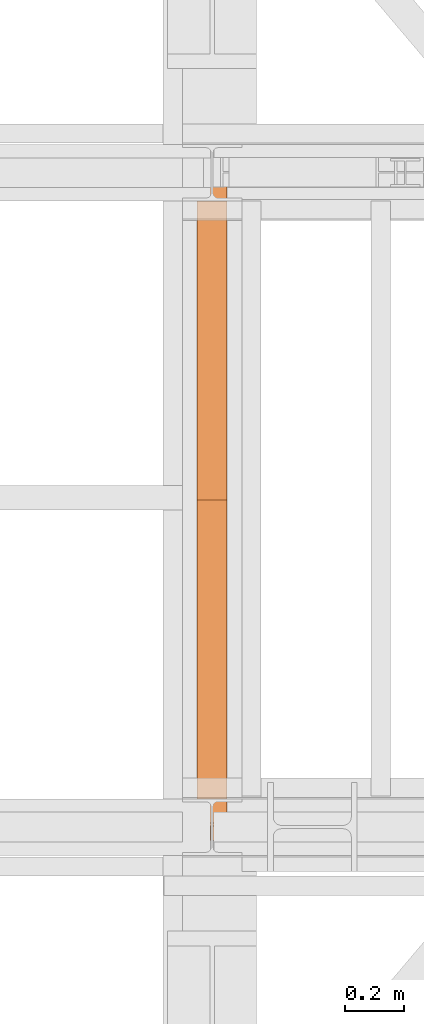
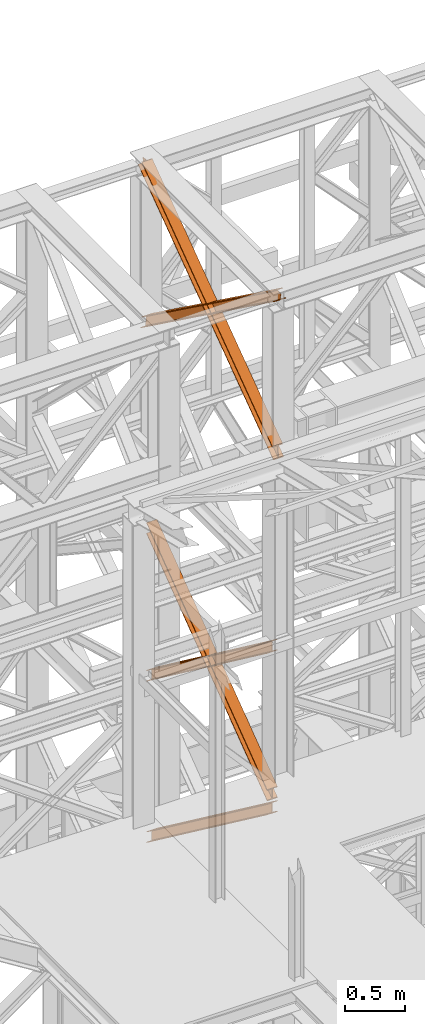
# One storey, part 125 of 208: 5 proxies.
"""IFC2X3 building model written with IfcOpenShell, lengths in millimetres."""

from ifc_helpers import new_model, entity, si_unit, converted_unit, frame, origin, origin_with_axes, place, context, subcontext, project, spatial, faceted_brep, element, save


model = new_model("IFC2X3")

# Units and contexts
model_context = context("Model", 3, precision=1e-05, world=origin())
plan_context = context("Plan", 3, precision=1e-05, world=origin())
body_context = subcontext(model_context, "Body", "Model", "MODEL_VIEW")
ifc_project = project(units=[si_unit("LENGTHUNIT", "METRE", prefix="MILLI"), converted_unit("PLANEANGLEUNIT", "DEGREE", entity("IfcPlaneAngleMeasure", 0.0174532925199433), si_unit("PLANEANGLEUNIT", "RADIAN"), dimensions=[0, 0, 0, 0, 0, 0, 0]), si_unit("AREAUNIT", "SQUARE_METRE"), si_unit("VOLUMEUNIT", "CUBIC_METRE")], contexts=[model_context, plan_context])

# Building, storey
building_placement = place(None, origin())
building = spatial("IfcBuilding", under=ifc_project, at=building_placement, CompositionType="COMPLEX")
storey_placement = place(building_placement, origin_with_axes())
storey = spatial("IfcBuildingStorey", under=building, at=storey_placement, Name="Geschoss", CompositionType="ELEMENT")

# Proxies
proxy_1_placement = place(storey_placement, frame((3243.082676642578, -15867.5743840594, 5504.219540188055), z_axis=(0.0, 0.0, 1.0), x_axis=(1.0, 0.0, 0.0)))
element("IfcBuildingElementProxy", 1, at=proxy_1_placement, inside=storey, context=body_context, shape_type="Brep", body=[
    faceted_brep([(100.0218596475406, 0.01000000000021828, 1511.076608371926), (100.1844513161013, 2010.009987483025, 9.820176864343011), (100.1855295209298, 2010.009987483025, 0.02100513655932446), (100.0229378523673, 0.01000000000021828, 1501.277436644132), (100.0229378523673, 0.01000000000021828, 1501.277436644132), (100.1855295209298, 2010.009987483025, 0.02100513655932446), (0.1855301264913578, 2010.009987483025, 0.01000000000021828), (0.02293845793246874, 0.01000000000021828, 1501.266431507576), (0.02293845793246874, 0.01000000000021828, 1501.266431507576), (0.1855301264913578, 2010.009987483025, 0.01000000000021828), (0.1844519216665503, 2010.009987483025, 9.809171727787543), (0.02186025310402329, 0.01000000000021828, 1511.06560323536), (0.02186025310402329, 0.01000000000021828, 1511.06560323536), (0.1844519216665503, 2010.009987483025, 9.809171727787543), (47.6844516340243, 2010.009987483025, 9.814399167646116), (47.52185996546359, 0.01000000000021828, 1511.070830675226), (47.52185996546359, 0.01000000000021828, 1511.070830675226), (47.6844516340243, 2010.009987483025, 9.814399167646116), (47.6736695857453, 2010.009987483025, 107.8061164454975), (47.51107791718459, 0.01000000000021828, 1609.062547953077), (47.51107791718459, 0.01000000000021828, 1609.062547953077), (47.6736695857453, 2010.009987483025, 107.8061164454975), (0.1736698733893718, 2010.009987483025, 107.8008890056317), (0.01107820482866373, 0.01000000000021828, 1609.057320513211), (0.01107820482866373, 0.01000000000021828, 1609.057320513211), (0.1736698733893718, 2010.009987483025, 107.8008890056317), (0.1725916685609263, 2010.009987483025, 117.6000607334227), (0.01000000000021828, 0.01000000000021828, 1618.856492240995), (0.01000000000021828, 0.01000000000021828, 1618.856492240995), (0.1725916685609263, 2010.009987483025, 117.6000607334227), (100.1725910629975, 2010.009987483025, 117.6110658699781), (100.009999394435, 0.01000000000021828, 1618.867497377558), (100.009999394435, 0.01000000000021828, 1618.867497377558), (100.1725910629975, 2010.009987483025, 117.6110658699781), (100.1736692678242, 2010.009987483025, 107.8118941421981), (100.0110775992634, 0.01000000000021828, 1609.068325649774), (100.0110775992634, 0.01000000000021828, 1609.068325649774), (100.1736692678242, 2010.009987483025, 107.8118941421981), (52.67366955546459, 2010.009987483025, 107.806666702325), (52.51107788690388, 0.01000000000021828, 1609.063098209905), (52.51107788690388, 0.01000000000021828, 1609.063098209905), (52.67366955546459, 2010.009987483025, 107.806666702325), (52.6844516037454, 2010.009987483025, 9.814949424477163), (52.52185993518287, 0.01000000000021828, 1511.071380932057), (52.52185993518287, 0.01000000000021828, 1511.071380932057), (52.6844516037454, 2010.009987483025, 9.814949424477163), (100.1844513161013, 2010.009987483025, 9.820176864343011), (100.0218596475406, 0.01000000000021828, 1511.076608371926), (100.1844513161013, 2010.009987483025, 9.820176864343011), (52.6844516037454, 2010.009987483025, 9.814949424477163), (52.67366955546459, 2010.009987483025, 107.806666702325), (100.1736692678242, 2010.009987483025, 107.8118941421981), (100.1725910629975, 2010.009987483025, 117.6110658699781), (0.1725916685609263, 2010.009987483025, 117.6000607334227), (0.1736698733893718, 2010.009987483025, 107.8008890056317), (47.6736695857453, 2010.009987483025, 107.8061164454975), (47.6844516340243, 2010.009987483025, 9.814399167646116), (0.1844519216665503, 2010.009987483025, 9.809171727787543), (0.1855301264913578, 2010.009987483025, 0.01000000000021828), (100.1855295209298, 2010.009987483025, 0.02100513655932446), (100.0229378523673, 0.01000000000021828, 1501.277436644132), (0.02293845793246874, 0.01000000000021828, 1501.266431507576), (0.02186025310402329, 0.01000000000021828, 1511.06560323536), (47.52185996546359, 0.01000000000021828, 1511.070830675226), (47.51107791718459, 0.01000000000021828, 1609.062547953077), (0.01107820482866373, 0.01000000000021828, 1609.057320513211), (0.01000000000021828, 0.01000000000021828, 1618.856492240995), (100.009999394435, 0.01000000000021828, 1618.867497377558), (100.0110775992634, 0.01000000000021828, 1609.068325649774), (52.51107788690388, 0.01000000000021828, 1609.063098209905), (52.52185993518287, 0.01000000000021828, 1511.071380932057), (100.0218596475406, 0.01000000000021828, 1511.076608371926)], [[[0, 1, 2, 3]], [[4, 5, 6, 7]], [[8, 9, 10, 11]], [[12, 13, 14, 15]], [[16, 17, 18, 19]], [[20, 21, 22, 23]], [[24, 25, 26, 27]], [[28, 29, 30, 31]], [[32, 33, 34, 35]], [[36, 37, 38, 39]], [[40, 41, 42, 43]], [[44, 45, 46, 47]], [[48, 49, 50, 51, 52, 53, 54, 55, 56, 57, 58, 59]], [[60, 61, 62, 63, 64, 65, 66, 67, 68, 69, 70, 71]]], orient=[[False], [False], [False], [False], [False], [False], [False], [False], [False], [False], [False], [False], [False], [False]]),
])
proxy_2_placement = place(storey_placement, frame((3242.895475356376, -15867.5743840594, 7147.441290649187), z_axis=(0.0, 0.0, 1.0), x_axis=(1.0, 0.0, 0.0)))
element("IfcBuildingElementProxy", 2, at=proxy_2_placement, inside=storey, context=body_context, shape_type="Brep", body=[
    faceted_brep([(100.0218623025612, 0.01000000000021828, 1512.063556389601), (100.1844166626906, 2010.009987483025, 9.822513400360549), (100.1854951088862, 2010.009987483025, 0.02100513655932446), (100.022940748755, 0.01000000000021828, 1502.262048125804), (100.022940748755, 0.01000000000021828, 1502.262048125804), (100.1854951088862, 2010.009987483025, 0.02100513655932446), (0.1854957144514629, 2010.009987483025, 0.01000000000021828), (0.02294135431839095, 0.01000000000021828, 1502.251042989237), (0.02294135431839095, 0.01000000000021828, 1502.251042989237), (0.1854957144514629, 2010.009987483025, 0.01000000000021828), (0.1844172682558565, 2010.009987483025, 9.811508263797805), (0.02186290812642255, 0.01000000000021828, 1512.052551253039), (0.02186290812642255, 0.01000000000021828, 1512.052551253039), (0.1844172682558565, 2010.009987483025, 9.811508263797805), (47.68441698061361, 2010.009987483025, 9.816735703663653), (47.52186262048235, 0.01000000000021828, 1512.057778692908), (47.52186262048235, 0.01000000000021828, 1512.057778692908), (47.68441698061361, 2010.009987483025, 9.816735703663653), (47.67363251868483, 2010.009987483025, 107.8318183416577), (47.51107815855175, 0.01000000000021828, 1610.072861330906), (47.51107815855175, 0.01000000000021828, 1610.072861330906), (47.67363251868483, 2010.009987483025, 107.8318183416577), (0.1736328063252586, 2010.009987483025, 107.8265909017955), (0.01107844619582465, 0.01000000000021828, 1610.067633891033), (0.01107844619582465, 0.01000000000021828, 1610.067633891033), (0.1736328063252586, 2010.009987483025, 107.8265909017955), (0.1725543601314712, 2010.009987483025, 117.6280991655931), (0.01000000000021828, 0.01000000000021828, 1619.86914215483), (0.01000000000021828, 0.01000000000021828, 1619.86914215483), (0.1725543601314712, 2010.009987483025, 117.6280991655931), (100.1725537545663, 2010.009987483025, 117.6391043021558), (100.009999394435, 0.01000000000021828, 1619.880147291397), (100.009999394435, 0.01000000000021828, 1619.880147291397), (100.1725537545663, 2010.009987483025, 117.6391043021558), (100.1736322007619, 2010.009987483025, 107.8375960383546), (100.0110778406306, 0.01000000000021828, 1610.078639027603), (100.0110778406306, 0.01000000000021828, 1610.078639027603), (100.1736322007619, 2010.009987483025, 107.8375960383546), (52.67363248840411, 2010.009987483025, 107.8323685984888), (52.51107812827468, 0.01000000000021828, 1610.073411587733), (52.51107812827468, 0.01000000000021828, 1610.073411587733), (52.67363248840411, 2010.009987483025, 107.8323685984888), (52.68441695033471, 2010.009987483025, 9.817285960491063), (52.52186259020346, 0.01000000000021828, 1512.058328949732), (52.52186259020346, 0.01000000000021828, 1512.058328949732), (52.68441695033471, 2010.009987483025, 9.817285960491063), (100.1844166626906, 2010.009987483025, 9.822513400360549), (100.0218623025612, 0.01000000000021828, 1512.063556389601), (100.1844166626906, 2010.009987483025, 9.822513400360549), (52.68441695033471, 2010.009987483025, 9.817285960491063), (52.67363248840411, 2010.009987483025, 107.8323685984888), (100.1736322007619, 2010.009987483025, 107.8375960383546), (100.1725537545663, 2010.009987483025, 117.6391043021558), (0.1725543601314712, 2010.009987483025, 117.6280991655931), (0.1736328063252586, 2010.009987483025, 107.8265909017955), (47.67363251868483, 2010.009987483025, 107.8318183416577), (47.68441698061361, 2010.009987483025, 9.816735703663653), (0.1844172682558565, 2010.009987483025, 9.811508263797805), (0.1854957144514629, 2010.009987483025, 0.01000000000021828), (100.1854951088862, 2010.009987483025, 0.02100513655932446), (100.022940748755, 0.01000000000021828, 1502.262048125804), (0.02294135431839095, 0.01000000000021828, 1502.251042989237), (0.02186290812642255, 0.01000000000021828, 1512.052551253039), (47.52186262048235, 0.01000000000021828, 1512.057778692908), (47.51107815855175, 0.01000000000021828, 1610.072861330906), (0.01107844619582465, 0.01000000000021828, 1610.067633891033), (0.01000000000021828, 0.01000000000021828, 1619.86914215483), (100.009999394435, 0.01000000000021828, 1619.880147291397), (100.0110778406306, 0.01000000000021828, 1610.078639027603), (52.51107812827468, 0.01000000000021828, 1610.073411587733), (52.52186259020346, 0.01000000000021828, 1512.058328949732), (100.0218623025612, 0.01000000000021828, 1512.063556389601)], [[[0, 1, 2, 3]], [[4, 5, 6, 7]], [[8, 9, 10, 11]], [[12, 13, 14, 15]], [[16, 17, 18, 19]], [[20, 21, 22, 23]], [[24, 25, 26, 27]], [[28, 29, 30, 31]], [[32, 33, 34, 35]], [[36, 37, 38, 39]], [[40, 41, 42, 43]], [[44, 45, 46, 47]], [[48, 49, 50, 51, 52, 53, 54, 55, 56, 57, 58, 59]], [[60, 61, 62, 63, 64, 65, 66, 67, 68, 69, 70, 71]]], orient=[[False], [False], [False], [False], [False], [False], [False], [False], [False], [False], [False], [False], [False], [False]]),
])
proxy_3_placement = place(storey_placement, frame((3242.895647595429, -15867.5743840594, 7147.394064575148), z_axis=(0.0, 0.0, 1.0), x_axis=(1.0, 0.0, 0.0)))
element("IfcBuildingElementProxy", 3, at=proxy_3_placement, inside=storey, context=body_context, shape_type="Brep", body=[
    faceted_brep([(100.0229386519513, 2010.009987483025, 1501.524522111415), (100.185572907496, 0.01000000000021828, 0.02100513656296243), (100.1844946360361, 0.01000000000021828, 9.82075546136366), (100.0218603804915, 2010.009987483025, 1511.324272436212), (0.02293925751655479, 2010.009987483025, 1501.513516974852), (0.185573513059353, 0.01000000000021828, 0.01000000000021828), (100.185572907496, 0.01000000000021828, 0.02100513656296243), (100.0229386519513, 2010.009987483025, 1501.524522111415), (0.02186098605488951, 2010.009987483025, 1511.313267299649), (0.1844952415995067, 0.01000000000021828, 9.809750324800916), (0.185573513059353, 0.01000000000021828, 0.01000000000021828), (0.02293925751655479, 2010.009987483025, 1501.513516974852), (47.52186069841264, 2010.009987483025, 1511.318494739518), (47.68449495395544, 0.01000000000021828, 9.814977764666764), (0.1844952415995067, 0.01000000000021828, 9.809750324800916), (0.02186098605488951, 2010.009987483025, 1511.313267299649), (47.51107798381418, 2010.009987483025, 1609.315997987507), (47.67371223936061, 0.01000000000021828, 107.8124810126556), (47.68449495395544, 0.01000000000021828, 9.814977764666764), (47.52186069841264, 2010.009987483025, 1511.318494739518), (0.01107827146006457, 2010.009987483025, 1609.310770547641), (0.1737125270028628, 0.01000000000021828, 107.8072535727861), (47.67371223936061, 0.01000000000021828, 107.8124810126556), (47.51107798381418, 2010.009987483025, 1609.315997987507), (0.01000000000021828, 2010.009987483025, 1619.110520872438), (0.1726342555448355, 0.01000000000021828, 117.6070038975868), (0.1737125270028628, 0.01000000000021828, 107.8072535727861), (0.01107827146006457, 2010.009987483025, 1609.310770547641), (100.009999394435, 2010.009987483025, 1619.121526009001), (100.1726336499778, 0.01000000000021828, 117.6180090341495), (0.1726342555448355, 0.01000000000021828, 117.6070038975868), (0.01000000000021828, 2010.009987483025, 1619.110520872438), (100.0110776658949, 2010.009987483025, 1609.321775684197), (100.1737119214376, 0.01000000000021828, 107.8182587093452), (100.1726336499778, 0.01000000000021828, 117.6180090341495), (100.009999394435, 2010.009987483025, 1619.121526009001), (52.5110779535371, 2010.009987483025, 1609.316548244331), (52.67371220908353, 0.01000000000021828, 107.8130312694793), (100.1737119214376, 0.01000000000021828, 107.8182587093452), (100.0110776658949, 2010.009987483025, 1609.321775684197), (52.52186066813374, 2010.009987483025, 1511.319044996339), (52.68449492368018, 0.01000000000021828, 9.815528021497812), (52.67371220908353, 0.01000000000021828, 107.8130312694793), (52.5110779535371, 2010.009987483025, 1609.316548244331), (100.0218603804915, 2010.009987483025, 1511.324272436212), (100.1844946360361, 0.01000000000021828, 9.82075546136366), (52.68449492368018, 0.01000000000021828, 9.815528021497812), (52.52186066813374, 2010.009987483025, 1511.319044996339), (100.185572907496, 0.01000000000021828, 0.02100513656296243), (0.185573513059353, 0.01000000000021828, 0.01000000000021828), (0.1844952415995067, 0.01000000000021828, 9.809750324800916), (47.68449495395544, 0.01000000000021828, 9.814977764666764), (47.67371223936061, 0.01000000000021828, 107.8124810126556), (0.1737125270028628, 0.01000000000021828, 107.8072535727861), (0.1726342555448355, 0.01000000000021828, 117.6070038975868), (100.1726336499778, 0.01000000000021828, 117.6180090341495), (100.1737119214376, 0.01000000000021828, 107.8182587093452), (52.67371220908353, 0.01000000000021828, 107.8130312694793), (52.68449492368018, 0.01000000000021828, 9.815528021497812), (100.1844946360361, 0.01000000000021828, 9.82075546136366), (100.0218603804915, 2010.009987483025, 1511.324272436212), (52.52186066813374, 2010.009987483025, 1511.319044996339), (52.5110779535371, 2010.009987483025, 1609.316548244331), (100.0110776658949, 2010.009987483025, 1609.321775684197), (100.009999394435, 2010.009987483025, 1619.121526009001), (0.01000000000021828, 2010.009987483025, 1619.110520872438), (0.01107827146006457, 2010.009987483025, 1609.310770547641), (47.51107798381418, 2010.009987483025, 1609.315997987507), (47.52186069841264, 2010.009987483025, 1511.318494739518), (0.02186098605488951, 2010.009987483025, 1511.313267299649), (0.02293925751655479, 2010.009987483025, 1501.513516974852), (100.0229386519513, 2010.009987483025, 1501.524522111415)], [[[0, 1, 2, 3]], [[4, 5, 6, 7]], [[8, 9, 10, 11]], [[12, 13, 14, 15]], [[16, 17, 18, 19]], [[20, 21, 22, 23]], [[24, 25, 26, 27]], [[28, 29, 30, 31]], [[32, 33, 34, 35]], [[36, 37, 38, 39]], [[40, 41, 42, 43]], [[44, 45, 46, 47]], [[48, 49, 50, 51, 52, 53, 54, 55, 56, 57, 58, 59]], [[60, 61, 62, 63, 64, 65, 66, 67, 68, 69, 70, 71]]], orient=[[False], [False], [False], [False], [False], [False], [False], [False], [False], [False], [False], [False], [False], [False]]),
])
proxy_4_placement = place(storey_placement, frame((3242.709402308909, -16015.63876149258, 10682.68948145022), z_axis=(0.0, 0.0, 1.0), x_axis=(1.0, 0.0, 0.0)))
element("IfcBuildingElementProxy", 4, at=proxy_4_placement, inside=storey, context=body_context, shape_type="Brep", body=[
    faceted_brep([(100.0210796676656, 2245.689626284609, 118.5389832593155), (100.1143745484151, 56.20017042807194, 1708.580236273849), (100.1148393871226, 67.43957130666058, 1710.120789741106), (100.0220869572258, 2244.212677303514, 129.3143453983157), (100.0220869572258, 2244.212677303514, 129.3143453983157), (100.1148393871226, 67.43957130666058, 1710.120789741106), (0.1148394121519232, 67.45274636205431, 1710.122490249456), (0.02208754364073684, 2244.212677303513, 129.3256138365559), (0.02208754364073684, 2244.212677303513, 129.3256138365559), (0.1148394121519232, 67.45274636205431, 1710.122490249456), (0.1143745734407275, 56.21334548348023, 1708.581936782199), (0.02108025408597314, 2245.689626284609, 118.5502516975485), (0.02108025408597314, 2245.689626284609, 118.5502516975485), (0.1143745734407275, 56.21334548348023, 1708.581936782199), (47.61437456155181, 56.20708733215906, 1708.581129040735), (47.52107997553685, 2245.689626284611, 118.5448991893809), (47.52107997553685, 2245.689626284611, 118.5448991893809), (47.61437456155181, 56.20708733215906, 1708.581129040735), (47.61205046476789, 0.010082544398756, 1700.878361650326), (47.60701710203466, 7.394829104428936, 1647.001538883871), (47.51100702250551, 2260.459116064767, 10.79127802407129), (47.51100702250551, 2260.459116064767, 10.79127802407129), (47.60701710203466, 7.394829104428936, 1647.001538883871), (0.107017380585603, 7.394829104430755, 1647.006891392024), (0.01100730106008996, 2260.459116064769, 10.79663053222066), (0.01100730106008996, 2260.459116064769, 10.79663053222066), (0.107017380585603, 7.394829104430755, 1647.006891392024), (0.1060107062494353, 8.871778415476001, 1636.231526845748), (0.01000000000021828, 2261.936065039698, 0.02126843821861257), (0.01000000000021828, 2261.936065039698, 0.02126843821861257), (0.1060107062494353, 8.871778415476001, 1636.231526845748), (100.1060101198273, 8.871778415472363, 1636.220258407533), (100.0099994135744, 2261.936065039694, 0.01000000000021828), (100.0099994135744, 2261.936065039694, 0.01000000000021828), (100.1060101198273, 8.871778415472363, 1636.220258407533), (100.1070167941634, 7.394829104425298, 1646.995622953813), (100.0110067146379, 2260.459116064765, 10.78536209401318), (100.0110067146379, 2260.459116064765, 10.78536209401318), (100.1070167941634, 7.394829104425298, 1646.995622953813), (52.60701707271619, 7.394829104428936, 1647.000975461962), (52.51100699318704, 2260.459116064767, 10.79071460216255), (52.51100699318704, 2260.459116064767, 10.79071460216255), (52.60701707271619, 7.394829104428936, 1647.000975461962), (52.61205048734519, 0.01000000000021828, 1700.878355604191), (52.61437456030035, 56.20642857939311, 1708.581044015316), (52.52107994621292, 2245.689626284609, 118.5443357674758), (52.52107994621292, 2245.689626284609, 118.5443357674758), (52.61437456030035, 56.20642857939311, 1708.581044015316), (100.1143745484151, 56.20017042807194, 1708.580236273849), (100.0210796676656, 2245.689626284609, 118.5389832593155), (100.1143745484151, 56.20017042807194, 1708.580236273849), (52.61437456030035, 56.20642857939311, 1708.581044015316), (52.61205048734519, 0.01000000000021828, 1700.878355604191), (47.61205046476789, 0.010082544398756, 1700.878361650326), (47.61437456155181, 56.20708733215906, 1708.581129040735), (0.1143745734407275, 56.21334548348023, 1708.581936782199), (0.1148394121519232, 67.45274636205431, 1710.122490249456), (100.1148393871226, 67.43957130666058, 1710.120789741106), (47.61205046476789, 0.010082544398756, 1700.878361650326), (52.61205048734519, 0.01000000000021828, 1700.878355604191), (52.60701707271619, 7.394829104428936, 1647.000975461962), (100.1070167941634, 7.394829104425298, 1646.995622953813), (100.1060101198273, 8.871778415472363, 1636.220258407533), (0.1060107062494353, 8.871778415476001, 1636.231526845748), (0.107017380585603, 7.394829104430755, 1647.006891392024), (47.60701710203466, 7.394829104428936, 1647.001538883871), (100.0220869572258, 2244.212677303514, 129.3143453983157), (0.02208754364073684, 2244.212677303513, 129.3256138365559), (0.02108025408597314, 2245.689626284609, 118.5502516975485), (47.52107997553685, 2245.689626284611, 118.5448991893809), (47.51100702250551, 2260.459116064767, 10.79127802407129), (0.01100730106008996, 2260.459116064769, 10.79663053222066), (0.01000000000021828, 2261.936065039698, 0.02126843821861257), (100.0099994135744, 2261.936065039694, 0.01000000000021828), (100.0110067146379, 2260.459116064765, 10.78536209401318), (52.51100699318704, 2260.459116064767, 10.79071460216255), (52.52107994621292, 2245.689626284609, 118.5443357674758), (100.0210796676656, 2245.689626284609, 118.5389832593155)], [[[0, 1, 2, 3]], [[4, 5, 6, 7]], [[8, 9, 10, 11]], [[12, 13, 14, 15]], [[16, 17, 18, 19, 20]], [[21, 22, 23, 24]], [[25, 26, 27, 28]], [[29, 30, 31, 32]], [[33, 34, 35, 36]], [[37, 38, 39, 40]], [[41, 42, 43, 44, 45]], [[46, 47, 48, 49]], [[50, 51, 52, 53, 54, 55, 56, 57]], [[58, 59, 60, 61, 62, 63, 64, 65]], [[66, 67, 68, 69, 70, 71, 72, 73, 74, 75, 76, 77]]], orient=[[False], [False], [False], [False], [False], [False], [False], [False], [False], [False], [False], [False], [False], [False], [False]]),
])
proxy_5_placement = place(storey_placement, frame((3242.729181833694, -15971.44366069647, 10682.68296591904), z_axis=(0.0, 0.0, 1.0), x_axis=(1.0, 0.0, 0.0)))
element("IfcBuildingElementProxy", 5, at=proxy_5_placement, inside=storey, context=body_context, shape_type="Brep", body=[
    faceted_brep([(100.0217932552368, 17.74853331263148, 129.3267546407205), (100.0912677831911, 2190.182945540866, 1706.987836358048), (100.0906922275608, 2201.421092011329, 1705.446286432978), (100.0208104383473, 16.27032220023102, 118.5503583986774), (0.02179387014803069, 17.74853331263148, 129.3386776252864), (0.09126795233532903, 2190.169006714281, 1706.989636715169), (100.0912677831911, 2190.182945540866, 1706.987836358048), (100.0217932552368, 17.74853331263148, 129.3267546407205), (0.0208110532585124, 16.27032220022738, 118.5622813832288), (0.09069239670316165, 2201.407153184735, 1705.448086790095), (0.09126795233532903, 2190.169006714281, 1706.989636715169), (0.02179387014803069, 17.74853331263148, 129.3386776252864), (47.52081076117611, 16.2703222002292, 118.5566179655598), (47.59069231636022, 2201.413774127363, 1705.447231620465), (0.09069239670316165, 2201.407153184735, 1705.448086790095), (0.0208110532585124, 16.27032220022738, 118.5622813832288), (47.51098253605778, 1.488211106367089, 10.79265576491343), (47.58304941302777, 2254.773823250514, 1647.169314498546), (47.58760831105064, 2261.634760381639, 1697.186647271237), (47.59069231636022, 2201.413774127363, 1705.447231620465), (47.52081076117611, 16.2703222002292, 118.5566179655598), (0.01098282814200502, 1.488211106363451, 10.79831918255331), (0.08304970511198917, 2254.773823250511, 1647.174977916204), (47.58304941302777, 2254.773823250514, 1647.169314498546), (47.51098253605778, 1.488211106367089, 10.79265576491343), (0.01000000000021828, 0.01000000000021828, 0.02192298452973773), (0.08206748974225775, 2253.295611815232, 1636.398579320261), (0.08304970511198917, 2254.773823250511, 1647.174977916204), (0.01098282814200502, 1.488211106363451, 10.79831918255331), (100.0099993850836, 0.01000000000567525, 0.01000000000021828), (100.0820668748293, 2253.29561181524, 1636.386656335728), (0.08206748974225775, 2253.295611815232, 1636.398579320261), (0.01000000000021828, 0.01000000000021828, 0.02192298452973773), (100.010982213229, 1.488211106370727, 10.78639619803107), (100.0830490901917, 2254.773823250516, 1647.163054931671), (100.0820668748293, 2253.29561181524, 1636.386656335728), (100.0099993850836, 0.01000000000567525, 0.01000000000021828), (52.51098250530595, 1.48821110636527, 10.79205961566731), (52.58304938227957, 2254.773823250514, 1647.168718349318), (100.0830490901917, 2254.773823250516, 1647.163054931671), (100.010982213229, 1.488211106370727, 10.78639619803107), (52.52081073042791, 16.27032220022738, 118.5560218163319), (52.59069230790374, 2201.414471068691, 1705.447141602608), (52.58760833413726, 2261.634841397497, 1697.186641740611), (52.58304938227957, 2254.773823250514, 1647.168718349318), (52.51098250530595, 1.48821110636527, 10.79205961566731), (100.0208104383473, 16.27032220023102, 118.5503583986774), (100.0906922275608, 2201.421092011329, 1705.446286432978), (52.59069230790374, 2201.414471068691, 1705.447141602608), (52.52081073042791, 16.27032220022738, 118.5560218163319), (100.0912677831911, 2190.182945540866, 1706.987836358048), (0.09126795233532903, 2190.169006714281, 1706.989636715169), (0.09069239670316165, 2201.407153184735, 1705.448086790095), (47.59069231636022, 2201.413774127363, 1705.447231620465), (47.58760831105064, 2261.634760381639, 1697.186647271237), (52.58760833413726, 2261.634841397497, 1697.186641740611), (52.59069230790374, 2201.414471068691, 1705.447141602608), (100.0906922275608, 2201.421092011329, 1705.446286432978), (47.58760831105064, 2261.634760381639, 1697.186647271237), (47.58304941302777, 2254.773823250514, 1647.169314498546), (0.08304970511198917, 2254.773823250511, 1647.174977916204), (0.08206748974225775, 2253.295611815232, 1636.398579320261), (100.0820668748293, 2253.29561181524, 1636.386656335728), (100.0830490901917, 2254.773823250516, 1647.163054931671), (52.58304938227957, 2254.773823250514, 1647.168718349318), (52.58760833413726, 2261.634841397497, 1697.186641740611), (100.0208104383473, 16.27032220023102, 118.5503583986774), (52.52081073042791, 16.27032220022738, 118.5560218163319), (52.51098250530595, 1.48821110636527, 10.79205961566731), (100.010982213229, 1.488211106370727, 10.78639619803107), (100.0099993850836, 0.01000000000567525, 0.01000000000021828), (0.01000000000021828, 0.01000000000021828, 0.02192298452973773), (0.01098282814200502, 1.488211106363451, 10.79831918255331), (47.51098253605778, 1.488211106367089, 10.79265576491343), (47.52081076117611, 16.2703222002292, 118.5566179655598), (0.0208110532585124, 16.27032220022738, 118.5622813832288), (0.02179387014803069, 17.74853331263148, 129.3386776252864), (100.0217932552368, 17.74853331263148, 129.3267546407205)], [[[0, 1, 2, 3]], [[4, 5, 6, 7]], [[8, 9, 10, 11]], [[12, 13, 14, 15]], [[16, 17, 18, 19, 20]], [[21, 22, 23, 24]], [[25, 26, 27, 28]], [[29, 30, 31, 32]], [[33, 34, 35, 36]], [[37, 38, 39, 40]], [[41, 42, 43, 44, 45]], [[46, 47, 48, 49]], [[50, 51, 52, 53, 54, 55, 56, 57]], [[58, 59, 60, 61, 62, 63, 64, 65]], [[66, 67, 68, 69, 70, 71, 72, 73, 74, 75, 76, 77]]], orient=[[False], [False], [False], [False], [False], [False], [False], [False], [False], [False], [False], [False], [False], [False], [False]]),
])

save(model, "model.ifc")
